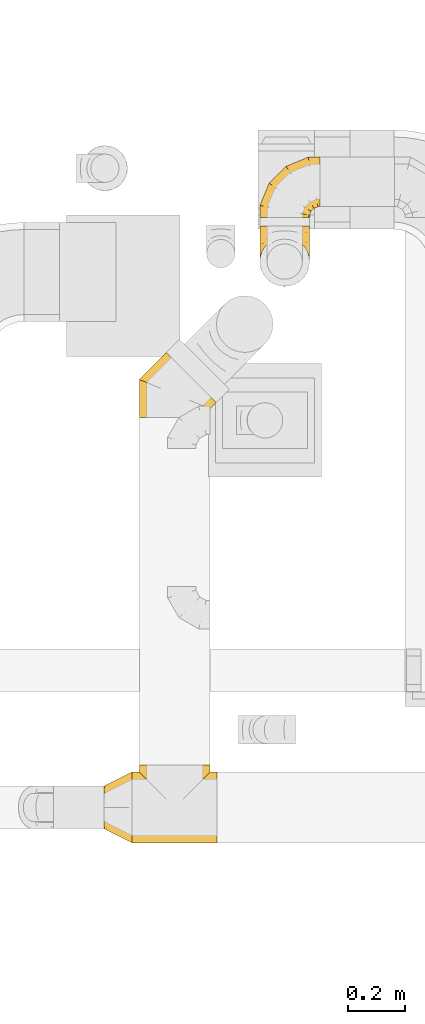
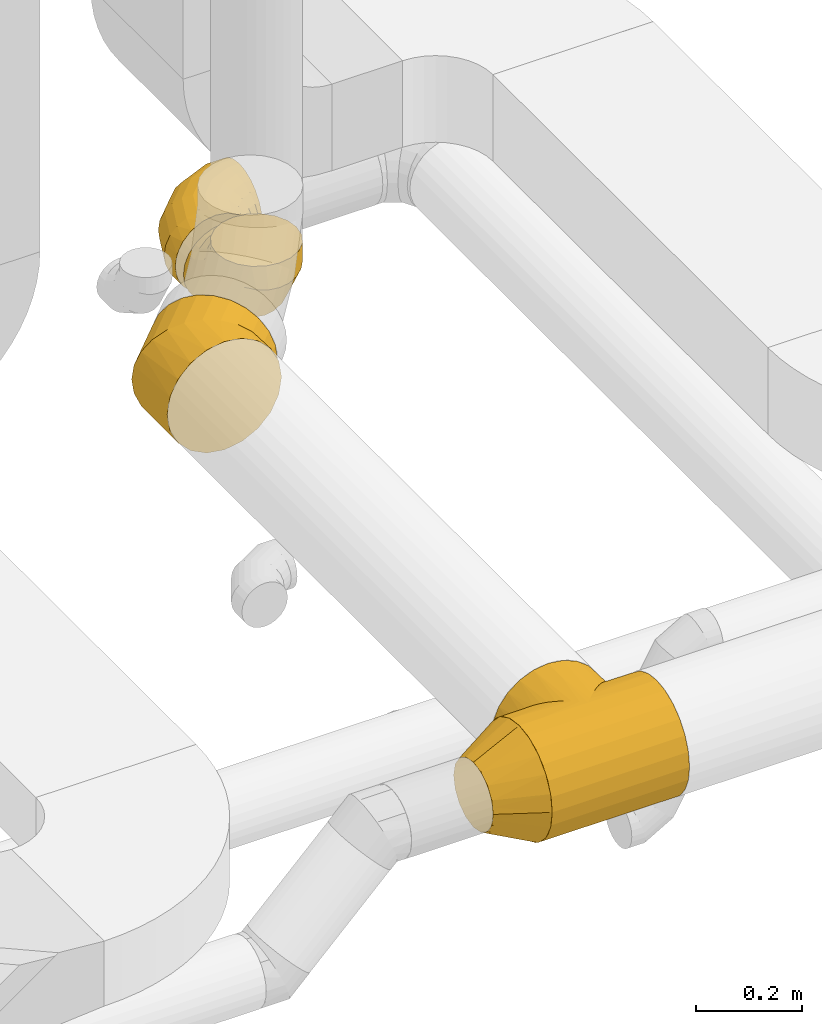
# One storey, part 23 of 97: 5 coverings.
"""IFC2X3 building model written with IfcOpenShell, lengths in millimetres."""

from ifc_helpers import new_model, entity, si_unit, converted_unit, derived_unit, direction, frame, origin, place, context, subcontext, project, spatial, faceted_brep, element, save


model = new_model("IFC2X3")

# Units and contexts
model_context = context("Model", 3, precision=0.01, world=origin(), true_north=direction((6.12303176911189e-17, 1.0)))
body_context = subcontext(model_context, "Body", "Model", "MODEL_VIEW")
ifc_project = project(units=[si_unit("LENGTHUNIT", "METRE", prefix="MILLI"), si_unit("AREAUNIT", "SQUARE_METRE"), si_unit("VOLUMEUNIT", "CUBIC_METRE"), converted_unit("PLANEANGLEUNIT", "DEGREE", entity("IfcRatioMeasure", 0.0174532925199433), si_unit("PLANEANGLEUNIT", "RADIAN"), dimensions=[0, 0, 0, 0, 0, 0, 0]), si_unit("MASSUNIT", "GRAM", prefix="KILO"), derived_unit("MASSDENSITYUNIT", [(si_unit("MASSUNIT", "GRAM", prefix="KILO"), 1), (si_unit("LENGTHUNIT", "METRE"), -3)]), derived_unit("MOMENTOFINERTIAUNIT", [(si_unit("LENGTHUNIT", "METRE"), 4)]), si_unit("TIMEUNIT", "SECOND"), si_unit("FREQUENCYUNIT", "HERTZ"), si_unit("THERMODYNAMICTEMPERATUREUNIT", "DEGREE_CELSIUS"), derived_unit("THERMALTRANSMITTANCEUNIT", [(si_unit("MASSUNIT", "GRAM", prefix="KILO"), 1), (si_unit("THERMODYNAMICTEMPERATUREUNIT", "KELVIN"), -1), (si_unit("TIMEUNIT", "SECOND"), -3)]), derived_unit("VOLUMETRICFLOWRATEUNIT", [(si_unit("LENGTHUNIT", "METRE"), 3), (si_unit("TIMEUNIT", "SECOND"), -1)]), derived_unit("MASSFLOWRATEUNIT", [(si_unit("MASSUNIT", "GRAM", prefix="KILO"), 1), (si_unit("TIMEUNIT", "SECOND"), -1)]), derived_unit("ROTATIONALFREQUENCYUNIT", [(si_unit("TIMEUNIT", "SECOND"), -1)]), si_unit("ELECTRICCURRENTUNIT", "AMPERE"), si_unit("ELECTRICVOLTAGEUNIT", "VOLT"), si_unit("POWERUNIT", "WATT"), si_unit("FORCEUNIT", "NEWTON", prefix="KILO"), si_unit("ILLUMINANCEUNIT", "LUX"), si_unit("LUMINOUSFLUXUNIT", "LUMEN"), si_unit("LUMINOUSINTENSITYUNIT", "CANDELA"), derived_unit("USERDEFINED", [(si_unit("MASSUNIT", "GRAM", prefix="KILO"), -1), (si_unit("LENGTHUNIT", "METRE"), -2), (si_unit("TIMEUNIT", "SECOND"), 3), (si_unit("LUMINOUSFLUXUNIT", "LUMEN"), 1)]), derived_unit("LINEARVELOCITYUNIT", [(si_unit("LENGTHUNIT", "METRE"), 1), (si_unit("TIMEUNIT", "SECOND"), -1)]), si_unit("PRESSUREUNIT", "PASCAL"), derived_unit("USERDEFINED", [(si_unit("LENGTHUNIT", "METRE"), -2), (si_unit("MASSUNIT", "GRAM", prefix="KILO"), 1), (si_unit("TIMEUNIT", "SECOND"), -2)]), derived_unit("LINEARFORCEUNIT", [(si_unit("MASSUNIT", "GRAM", prefix="KILO"), 1), (si_unit("LENGTHUNIT", "METRE"), 1), (si_unit("TIMEUNIT", "SECOND"), -2), (si_unit("LENGTHUNIT", "METRE"), -1)]), derived_unit("PLANARFORCEUNIT", [(si_unit("MASSUNIT", "GRAM", prefix="KILO"), 1), (si_unit("LENGTHUNIT", "METRE"), 1), (si_unit("TIMEUNIT", "SECOND"), -2), (si_unit("LENGTHUNIT", "METRE"), -2)])], contexts=[model_context])

# Site, building, storey
site_placement = place(None, origin())
site = spatial("IfcSite", under=ifc_project, at=site_placement, CompositionType="ELEMENT")
building_placement = place(site_placement, origin())
building = spatial("IfcBuilding", under=site, at=building_placement, CompositionType="ELEMENT")
storey_placement = place(building_placement, frame((0.0, 0.0, -4900.0)))
storey = spatial("IfcBuildingStorey", under=building, at=storey_placement, CompositionType="ELEMENT", Elevation=-4900.0)

# Coverings
covering_1_placement = place(storey_placement, frame((59460.9, 11435.8, 4025.9)))
element("IfcCovering", 1, at=covering_1_placement, inside=storey, PredefinedType="INSULATION", context=body_context, shape_type="Brep", body=[
    faceted_brep([(5.88, 116.13, 214.1), (1.6, 89.1, 214.1), (5.88, 62.06, 214.1), (18.31, 37.66, 214.1), (37.66, 18.31, 214.1), (62.06, 5.88, 214.1), (89.1, 1.6, 214.1), (116.13, 5.88, 214.1), (140.53, 18.31, 214.1), (159.88, 37.66, 214.1), (172.31, 62.06, 214.1), (176.6, 89.1, 214.1), (172.31, 116.13, 214.1), (159.88, 140.53, 214.1), (140.53, 159.88, 214.1), (128.33, 166.1, 214.1), (116.13, 172.31, 214.1), (102.61, 174.45, 214.1), (89.1, 176.6, 214.1), (75.58, 174.45, 214.1), (62.06, 172.31, 214.1), (49.86, 166.1, 214.1), (37.66, 159.88, 214.1), (18.31, 140.53, 214.1), (132.85, 214.1, 13.32), (111.74, 214.1, 4.58), (89.1, 214.1, 1.6), (66.45, 214.1, 4.58), (45.35, 214.1, 13.32), (27.22, 214.1, 27.22), (13.32, 214.1, 45.35), (4.58, 214.1, 66.45), (1.6, 214.1, 89.1), (4.58, 214.1, 111.74), (13.32, 214.1, 132.85), (27.22, 214.1, 150.97), (45.35, 214.1, 164.87), (66.45, 214.1, 173.61), (89.1, 214.1, 176.6), (111.74, 214.1, 173.61), (132.85, 214.1, 164.87), (150.97, 214.1, 150.97), (164.87, 214.1, 132.85), (173.61, 214.1, 111.74), (176.6, 214.1, 89.1), (173.61, 214.1, 66.45), (164.87, 214.1, 45.35), (150.97, 214.1, 27.22), (89.1, 157.16, 1.6), (66.45, 157.95, 4.58), (45.35, 160.3, 13.32), (27.22, 164.02, 27.22), (13.32, 168.88, 45.35), (4.58, 174.53, 66.45), (1.6, 180.6, 89.1), (4.58, 186.67, 111.74), (13.32, 192.32, 132.85), (27.22, 197.18, 150.97), (45.35, 200.91, 164.87), (66.45, 203.25, 173.61), (89.1, 204.05, 176.6), (111.74, 203.25, 173.61), (132.85, 200.91, 164.87), (150.97, 197.18, 150.97), (173.61, 186.67, 111.74), (176.6, 180.6, 89.1), (164.87, 192.32, 132.85), (173.61, 174.53, 66.45), (164.87, 168.88, 45.35), (150.97, 164.02, 27.22), (132.85, 160.3, 13.32), (111.74, 157.95, 4.58), (89.1, 58.53, 58.53), (66.45, 60.72, 60.72), (45.35, 67.12, 67.12), (27.22, 77.3, 77.3), (13.32, 90.56, 90.56), (4.58, 106.01, 106.01), (1.6, 122.59, 122.59), (4.58, 139.17, 139.17), (13.32, 154.62, 154.62), (27.22, 167.88, 167.88), (45.35, 178.06, 178.06), (66.45, 184.46, 184.46), (89.1, 186.64, 186.64), (111.74, 184.46, 184.46), (132.85, 178.06, 178.06), (150.97, 167.88, 167.88), (173.61, 139.17, 139.17), (176.6, 122.59, 122.59), (164.87, 154.62, 154.62), (173.61, 106.01, 106.01), (164.87, 90.56, 90.56), (150.97, 77.3, 77.3), (132.85, 67.12, 67.12), (111.74, 60.72, 60.72), (89.1, 1.6, 157.16), (66.45, 4.58, 157.95), (45.35, 13.32, 160.3), (27.22, 27.22, 164.02), (13.32, 45.35, 168.88), (4.58, 66.45, 174.53), (1.6, 89.1, 180.6), (4.58, 111.74, 186.67), (13.32, 132.85, 192.32), (27.22, 150.97, 197.18), (45.35, 164.87, 200.91), (66.45, 173.61, 203.25), (77.77, 175.1, 203.65), (89.1, 176.6, 204.05), (111.74, 173.61, 203.25), (132.85, 164.87, 200.91), (100.42, 175.1, 203.65), (150.97, 150.97, 197.18), (173.61, 111.74, 186.67), (176.6, 89.1, 180.6), (164.87, 132.85, 192.32), (173.61, 66.45, 174.53), (164.87, 45.35, 168.88), (150.97, 27.22, 164.02), (132.85, 13.32, 160.3), (111.74, 4.58, 157.95)], [[[0, 1, 2, 3, 4, 5, 6, 7, 8, 9, 10, 11, 12, 13, 14, 15, 16, 17, 18, 19, 20, 21, 22, 23]], [[24, 25, 26, 27, 28, 29, 30, 31, 32, 33, 34, 35, 36, 37, 38, 39, 40, 41, 42, 43, 44, 45, 46, 47]], [[26, 48, 49, 27]], [[27, 49, 50, 28]], [[28, 50, 51, 29]], [[30, 52, 53, 31]], [[31, 53, 54, 32]], [[29, 51, 52, 30]], [[55, 56, 34, 33]], [[54, 55, 33, 32]], [[57, 35, 34, 56]], [[58, 59, 37, 36]], [[58, 36, 35, 57]], [[60, 38, 37, 59]], [[61, 62, 40, 39]], [[60, 61, 39, 38]], [[41, 40, 62, 63]], [[64, 65, 44, 43]], [[66, 64, 43, 42]], [[63, 66, 42, 41]], [[46, 45, 67, 68]], [[47, 46, 68, 69]], [[44, 65, 67, 45]], [[25, 24, 70, 71]], [[26, 25, 71, 48]], [[69, 70, 24, 47]], [[49, 48, 72, 73]], [[50, 49, 73, 74]], [[74, 75, 51, 50]], [[52, 51, 75, 76]], [[53, 52, 76, 77]], [[54, 53, 77, 78]], [[79, 80, 56, 55]], [[78, 79, 55, 54]], [[57, 56, 80, 81]], [[82, 83, 59, 58]], [[81, 82, 58, 57]], [[60, 59, 83, 84]], [[85, 86, 62, 61]], [[84, 85, 61, 60]], [[63, 62, 86, 87]], [[88, 89, 65, 64]], [[90, 88, 64, 66]], [[87, 90, 66, 63]], [[67, 65, 89, 91]], [[68, 67, 91, 92]], [[69, 68, 92, 93]], [[71, 70, 94, 95]], [[48, 71, 95, 72]], [[93, 94, 70, 69]], [[73, 72, 96, 97]], [[74, 73, 97, 98]], [[98, 99, 75, 74]], [[76, 75, 99, 100]], [[77, 76, 100, 101]], [[78, 77, 101, 102]], [[103, 104, 80, 79]], [[102, 103, 79, 78]], [[81, 80, 104, 105]], [[106, 107, 83, 82]], [[105, 106, 82, 81]], [[84, 83, 107, 108, 109]], [[110, 111, 86, 85]], [[85, 84, 109, 112, 110]], [[87, 86, 111, 113]], [[114, 115, 89, 88]], [[116, 114, 88, 90]], [[113, 116, 90, 87]], [[91, 89, 115, 117]], [[92, 91, 117, 118]], [[93, 92, 118, 119]], [[95, 94, 120, 121]], [[72, 95, 121, 96]], [[119, 120, 94, 93]], [[97, 6, 5]], [[98, 5, 4]], [[6, 97, 96]], [[97, 5, 98]], [[4, 99, 98]], [[100, 3, 2]], [[101, 2, 1]], [[99, 3, 100]], [[100, 2, 101]], [[1, 102, 101]], [[3, 99, 4]], [[103, 1, 0]], [[104, 0, 23]], [[103, 102, 1]], [[104, 103, 0]], [[23, 105, 104]], [[21, 20, 107]], [[18, 109, 108]], [[107, 20, 19]], [[106, 105, 22]], [[106, 22, 21]], [[107, 19, 108]], [[21, 107, 106]], [[18, 108, 19]], [[22, 105, 23]], [[110, 17, 16]], [[111, 15, 14]], [[18, 112, 109]], [[18, 17, 112]], [[110, 16, 15]], [[110, 15, 111]], [[14, 113, 111]], [[116, 13, 12]], [[114, 12, 11]], [[116, 113, 13]], [[115, 114, 11]], [[116, 12, 114]], [[17, 110, 112]], [[13, 113, 14]], [[117, 11, 10]], [[118, 10, 9]], [[11, 117, 115]], [[117, 10, 118]], [[9, 119, 118]], [[120, 8, 7]], [[121, 7, 6]], [[119, 8, 120]], [[121, 120, 7]], [[96, 121, 6]], [[8, 119, 9]]]),
])
covering_2_placement = place(storey_placement, frame((59460.9, 11680.87, 4025.9)))
element("IfcCovering", 2, at=covering_2_placement, inside=storey, PredefinedType="INSULATION", context=body_context, shape_type="Brep", body=[
    faceted_brep([(116.13, 0.0, 172.31), (89.1, 0.0, 176.6), (62.06, 0.0, 172.31), (37.66, 0.0, 159.88), (18.31, 0.0, 140.53), (5.88, 0.0, 116.13), (1.6, 0.0, 89.1), (5.88, 0.0, 62.06), (18.31, 0.0, 37.66), (37.66, 0.0, 18.31), (62.06, 0.0, 5.88), (89.1, 0.0, 1.6), (116.13, 0.0, 5.88), (140.53, 0.0, 18.31), (159.88, 0.0, 37.66), (166.1, 0.0, 49.86), (172.31, 0.0, 62.06), (174.45, 0.0, 75.58), (176.6, 0.0, 89.1), (174.45, 0.0, 102.61), (172.31, 0.0, 116.13), (166.1, 0.0, 128.33), (159.88, 0.0, 140.53), (140.53, 0.0, 159.88), (214.1, 200.78, 45.35), (214.1, 209.52, 66.45), (214.1, 212.5, 89.1), (214.1, 209.52, 111.74), (214.1, 200.78, 132.85), (214.1, 186.87, 150.97), (214.1, 168.75, 164.87), (214.1, 147.65, 173.61), (214.1, 125.0, 176.6), (214.1, 102.35, 173.61), (214.1, 81.25, 164.87), (214.1, 63.13, 150.97), (214.1, 49.22, 132.85), (214.1, 40.48, 111.74), (214.1, 37.5, 89.1), (214.1, 40.48, 66.45), (214.1, 49.22, 45.35), (214.1, 63.13, 27.22), (214.1, 81.25, 13.32), (214.1, 102.35, 4.58), (214.1, 125.0, 1.6), (214.1, 147.65, 4.58), (214.1, 168.75, 13.32), (214.1, 186.87, 27.22), (171.83, 212.5, 89.1), (172.42, 209.52, 111.74), (174.16, 200.78, 132.85), (176.92, 186.87, 150.97), (180.53, 168.75, 164.87), (184.73, 147.65, 173.61), (189.23, 125.0, 176.6), (193.74, 102.35, 173.61), (197.93, 81.25, 164.87), (201.54, 63.13, 150.97), (206.04, 40.48, 111.74), (206.64, 37.5, 89.1), (204.3, 49.22, 132.85), (204.3, 49.22, 45.35), (201.54, 63.13, 27.22), (206.04, 40.48, 66.45), (193.74, 102.35, 4.58), (189.23, 125.0, 1.6), (197.93, 81.25, 13.32), (184.73, 147.65, 4.58), (180.53, 168.75, 13.32), (176.92, 186.87, 27.22), (174.16, 200.78, 45.35), (172.42, 209.52, 66.45), (93.72, 180.15, 89.1), (95.41, 177.62, 111.74), (100.36, 170.21, 132.85), (108.24, 158.42, 150.97), (118.51, 143.06, 164.87), (130.46, 125.17, 173.61), (143.29, 105.97, 176.6), (156.12, 86.77, 173.61), (168.07, 68.88, 164.87), (178.34, 53.52, 150.97), (191.16, 34.32, 111.74), (192.85, 31.79, 89.1), (186.21, 41.73, 132.85), (186.21, 41.73, 45.35), (178.34, 53.52, 27.22), (191.16, 34.32, 66.45), (156.12, 86.77, 4.58), (143.29, 105.97, 1.6), (168.07, 68.88, 13.32), (130.46, 125.17, 4.58), (118.51, 143.06, 13.32), (108.24, 158.42, 27.22), (100.36, 170.21, 45.35), (95.41, 177.62, 66.45), (33.95, 120.37, 89.1), (36.47, 118.68, 111.74), (43.88, 113.73, 132.85), (55.67, 105.85, 150.97), (71.04, 95.59, 164.87), (88.93, 83.64, 173.61), (108.13, 70.81, 176.6), (127.32, 57.98, 173.61), (145.21, 46.02, 164.87), (160.58, 35.76, 150.97), (179.78, 22.93, 111.74), (182.3, 21.24, 89.1), (172.37, 27.88, 132.85), (172.37, 27.88, 45.35), (160.58, 35.76, 27.22), (179.78, 22.93, 66.45), (127.32, 57.98, 4.58), (108.13, 70.81, 1.6), (145.21, 46.02, 13.32), (88.93, 83.64, 4.58), (71.04, 95.59, 13.32), (55.67, 105.85, 27.22), (43.88, 113.73, 45.35), (36.47, 118.68, 66.45), (1.6, 42.27, 89.1), (4.58, 41.68, 111.74), (13.32, 39.94, 132.85), (27.22, 37.17, 150.97), (45.35, 33.57, 164.87), (66.45, 29.37, 173.61), (89.1, 24.86, 176.6), (111.74, 20.36, 173.61), (132.85, 16.16, 164.87), (150.97, 12.56, 150.97), (173.61, 8.05, 111.74), (175.1, 7.76, 100.42), (176.6, 7.46, 89.1), (164.87, 9.79, 132.85), (164.87, 9.79, 45.35), (150.97, 12.56, 27.22), (173.61, 8.05, 66.45), (175.1, 7.76, 77.77), (111.74, 20.36, 4.58), (89.1, 24.86, 1.6), (132.85, 16.16, 13.32), (66.45, 29.37, 4.58), (45.35, 33.57, 13.32), (27.22, 37.17, 27.22), (13.32, 39.94, 45.35), (4.58, 41.68, 66.45)], [[[0, 1, 2, 3, 4, 5, 6, 7, 8, 9, 10, 11, 12, 13, 14, 15, 16, 17, 18, 19, 20, 21, 22, 23]], [[24, 25, 26, 27, 28, 29, 30, 31, 32, 33, 34, 35, 36, 37, 38, 39, 40, 41, 42, 43, 44, 45, 46, 47]], [[26, 48, 49, 27]], [[27, 49, 50, 28]], [[28, 50, 51, 29]], [[30, 52, 53, 31]], [[31, 53, 54, 32]], [[30, 29, 51, 52]], [[55, 56, 34, 33]], [[54, 55, 33, 32]], [[34, 56, 57, 35]], [[58, 59, 38, 37]], [[60, 58, 37, 36]], [[35, 57, 60, 36]], [[40, 61, 62, 41]], [[63, 61, 40, 39]], [[38, 59, 63, 39]], [[64, 65, 44, 43]], [[66, 64, 43, 42]], [[62, 66, 42, 41]], [[46, 45, 67, 68]], [[47, 46, 68, 69]], [[44, 65, 67, 45]], [[25, 24, 70, 71]], [[26, 25, 71, 48]], [[69, 70, 24, 47]], [[49, 48, 72, 73]], [[50, 49, 73, 74]], [[74, 75, 51, 50]], [[52, 51, 75, 76]], [[53, 52, 76, 77]], [[54, 53, 77, 78]], [[79, 80, 56, 55]], [[78, 79, 55, 54]], [[56, 80, 81, 57]], [[82, 83, 59, 58]], [[84, 82, 58, 60]], [[60, 57, 81, 84]], [[85, 86, 62, 61]], [[87, 85, 61, 63]], [[83, 87, 63, 59]], [[88, 89, 65, 64]], [[90, 88, 64, 66]], [[66, 62, 86, 90]], [[67, 65, 89, 91]], [[68, 67, 91, 92]], [[69, 68, 92, 93]], [[71, 70, 94, 95]], [[48, 71, 95, 72]], [[93, 94, 70, 69]], [[73, 72, 96, 97]], [[74, 73, 97, 98]], [[98, 99, 75, 74]], [[76, 75, 99, 100]], [[77, 76, 100, 101]], [[78, 77, 101, 102]], [[103, 104, 80, 79]], [[102, 103, 79, 78]], [[80, 104, 105, 81]], [[106, 107, 83, 82]], [[108, 106, 82, 84]], [[84, 81, 105, 108]], [[109, 110, 86, 85]], [[111, 109, 85, 87]], [[107, 111, 87, 83]], [[112, 113, 89, 88]], [[114, 112, 88, 90]], [[90, 86, 110, 114]], [[91, 89, 113, 115]], [[92, 91, 115, 116]], [[93, 92, 116, 117]], [[95, 94, 118, 119]], [[72, 95, 119, 96]], [[117, 118, 94, 93]], [[97, 96, 120, 121]], [[98, 97, 121, 122]], [[122, 123, 99, 98]], [[100, 99, 123, 124]], [[101, 100, 124, 125]], [[102, 101, 125, 126]], [[127, 128, 104, 103]], [[126, 127, 103, 102]], [[104, 128, 129, 105]], [[107, 106, 130, 131, 132]], [[133, 130, 106, 108]], [[108, 105, 129, 133]], [[134, 135, 110, 109]], [[136, 134, 109, 111]], [[107, 132, 137, 136, 111]], [[138, 139, 113, 112]], [[140, 138, 112, 114]], [[114, 110, 135, 140]], [[115, 113, 139, 141]], [[116, 115, 141, 142]], [[117, 116, 142, 143]], [[119, 118, 144, 145]], [[96, 119, 145, 120]], [[143, 144, 118, 117]], [[121, 6, 5]], [[122, 5, 4]], [[6, 121, 120]], [[121, 5, 122]], [[4, 123, 122]], [[2, 1, 125]], [[3, 2, 124]], [[123, 3, 124]], [[124, 2, 125]], [[1, 126, 125]], [[3, 123, 4]], [[127, 1, 0]], [[128, 0, 23]], [[127, 126, 1]], [[128, 127, 0]], [[23, 129, 128]], [[21, 20, 130]], [[18, 132, 131]], [[130, 20, 19]], [[133, 129, 22]], [[133, 22, 21]], [[130, 19, 131]], [[21, 130, 133]], [[18, 131, 19]], [[22, 129, 23]], [[136, 17, 16]], [[134, 15, 14]], [[18, 137, 132]], [[18, 17, 137]], [[136, 16, 15]], [[136, 15, 134]], [[14, 135, 134]], [[140, 13, 12]], [[138, 12, 11]], [[140, 135, 13]], [[139, 138, 11]], [[140, 12, 138]], [[17, 136, 137]], [[13, 135, 14]], [[141, 11, 10]], [[142, 10, 9]], [[11, 141, 139]], [[141, 10, 142]], [[9, 143, 142]], [[144, 8, 7]], [[145, 7, 6]], [[143, 8, 144]], [[145, 144, 7]], [[120, 145, 6]], [[8, 143, 9]]]),
])
covering_3_placement = place(storey_placement, frame((59035.41, 10974.41, 4223.4)))
element("IfcCovering", 3, at=covering_3_placement, inside=storey, PredefinedType="INSULATION", context=body_context, shape_type="Brep", body=[
    faceted_brep([(251.6, 0.0, 126.6), (245.48, 0.0, 165.22), (227.72, 0.0, 200.07), (200.07, 0.0, 227.72), (165.22, 0.0, 245.48), (126.6, 0.0, 251.6), (87.97, 0.0, 245.48), (53.12, 0.0, 227.72), (25.47, 0.0, 200.07), (7.71, 0.0, 165.22), (1.6, 0.0, 126.6), (7.71, 0.0, 87.97), (25.47, 0.0, 53.12), (53.12, 0.0, 25.47), (87.97, 0.0, 7.71), (126.6, 0.0, 1.6), (165.22, 0.0, 7.71), (200.07, 0.0, 25.47), (227.72, 0.0, 53.12), (245.48, 0.0, 87.97), (99.8, 226.8, 94.24), (96.79, 229.81, 126.6), (99.8, 226.8, 158.95), (108.63, 217.97, 189.1), (122.67, 203.92, 214.98), (140.98, 185.62, 234.85), (162.3, 164.3, 247.34), (185.17, 141.42, 251.6), (208.05, 118.54, 247.34), (229.37, 97.23, 234.85), (247.67, 78.92, 214.98), (261.72, 64.87, 189.1), (270.55, 56.04, 158.95), (273.56, 53.03, 126.6), (270.55, 56.04, 94.24), (261.72, 64.87, 64.1), (247.67, 78.92, 38.21), (229.37, 97.23, 18.34), (208.05, 118.54, 5.85), (185.17, 141.42, 1.6), (162.3, 164.3, 5.85), (140.98, 185.62, 18.34), (122.67, 203.92, 38.21), (108.63, 217.97, 64.1), (1.6, 134.62, 126.6), (5.85, 132.86, 158.95), (18.34, 127.68, 189.1), (38.21, 119.45, 214.98), (64.1, 108.73, 234.85), (94.24, 96.24, 247.34), (126.6, 82.84, 251.6), (158.95, 69.44, 247.34), (189.1, 56.95, 234.85), (214.98, 46.23, 214.98), (247.34, 32.83, 158.95), (251.6, 31.07, 126.6), (234.85, 38.0, 189.1), (234.85, 38.0, 64.1), (214.98, 46.23, 38.21), (247.34, 32.83, 94.24), (158.95, 69.44, 5.85), (126.6, 82.84, 1.6), (189.1, 56.95, 18.34), (94.24, 96.24, 5.85), (64.1, 108.73, 18.34), (38.21, 119.45, 38.21), (18.34, 127.68, 64.1), (5.85, 132.86, 94.24)], [[[0, 1, 2, 3, 4, 5, 6, 7, 8, 9, 10, 11, 12, 13, 14, 15, 16, 17, 18, 19]], [[20, 21, 22, 23, 24, 25, 26, 27, 28, 29, 30, 31, 32, 33, 34, 35, 36, 37, 38, 39, 40, 41, 42, 43]], [[21, 44, 45, 22]], [[22, 45, 46, 23]], [[47, 24, 23, 46]], [[24, 47, 48, 25]], [[25, 48, 49, 26]], [[50, 27, 26, 49]], [[51, 52, 29, 28]], [[50, 51, 28, 27]], [[29, 52, 53, 30]], [[54, 55, 33, 32]], [[56, 54, 32, 31]], [[30, 53, 56, 31]], [[35, 57, 58, 36]], [[59, 57, 35, 34]], [[33, 55, 59, 34]], [[60, 61, 39, 38]], [[62, 60, 38, 37]], [[58, 62, 37, 36]], [[40, 39, 61, 63]], [[41, 40, 63, 64]], [[64, 65, 42, 41]], [[20, 43, 66, 67]], [[21, 20, 67, 44]], [[65, 66, 43, 42]], [[9, 8, 46]], [[10, 9, 45]], [[10, 45, 44]], [[45, 9, 46]], [[8, 47, 46]], [[48, 7, 6]], [[49, 6, 5]], [[47, 7, 48]], [[48, 6, 49]], [[5, 50, 49]], [[7, 47, 8]], [[4, 3, 52]], [[5, 4, 51]], [[51, 50, 5]], [[52, 51, 4]], [[3, 53, 52]], [[56, 2, 1]], [[54, 1, 0]], [[56, 53, 2]], [[55, 54, 0]], [[56, 1, 54]], [[2, 53, 3]], [[19, 18, 57]], [[0, 19, 59]], [[59, 55, 0]], [[57, 59, 19]], [[18, 58, 57]], [[62, 17, 16]], [[60, 16, 15]], [[62, 58, 17]], [[61, 60, 15]], [[62, 16, 60]], [[17, 58, 18]], [[63, 15, 14]], [[64, 14, 13]], [[15, 63, 61]], [[63, 14, 64]], [[13, 65, 64]], [[66, 12, 11]], [[67, 11, 10]], [[65, 12, 66]], [[67, 66, 11]], [[44, 67, 10]], [[12, 65, 13]]]),
])
covering_4_placement = place(storey_placement, frame((59012.01, 9472.39, 4223.4)))
element("IfcCovering", 4, at=covering_4_placement, inside=storey, PredefinedType="INSULATION", context=body_context, shape_type="Brep", body=[
    faceted_brep([(247.6, 126.6, 251.6), (300.0, 158.95, 247.34), (172.44, 149.03, 249.57), (300.0, 189.1, 234.85), (225.83, 202.43, 225.96), (215.72, 192.31, 232.93), (300.0, 214.98, 214.98), (205.24, 181.84, 238.73), (300.0, 126.6, 251.6), (0.0, 158.95, 247.34), (0.0, 126.6, 251.6), (52.4, 126.6, 251.6), (161.24, 137.84, 251.09), (194.49, 171.09, 243.41), (183.54, 160.13, 247.01), (300.0, 234.85, 189.1), (252.86, 229.45, 197.63), (300.0, 224.92, 202.04), (300.0, 247.34, 158.95), (266.36, 242.96, 172.25), (300.0, 241.09, 174.02), (273.99, 250.59, 142.43), (300.0, 251.6, 126.6), (275.0, 251.6, 126.6), (26.01, 250.59, 142.43), (25.0, 251.6, 126.6), (0.0, 251.6, 126.6), (300.0, 249.47, 142.77), (244.55, 221.14, 208.36), (271.05, 247.64, 157.78), (235.49, 212.08, 217.79), (150.0, 126.6, 251.6), (138.76, 137.84, 251.09), (260.21, 236.81, 185.58), (300.0, 249.47, 110.42), (0.0, 249.47, 110.42), (265.16, 241.75, 77.98), (300.0, 241.09, 79.17), (300.0, 234.85, 64.1), (300.0, 247.34, 94.24), (273.84, 250.44, 109.63), (300.0, 224.92, 51.15), (300.0, 214.98, 38.21), (240.75, 217.35, 40.63), (270.48, 247.07, 93.27), (258.22, 234.81, 64.04), (249.99, 226.58, 51.58), (230.73, 207.32, 31.16), (220.11, 196.7, 23.11), (300.0, 189.1, 18.34), (197.59, 174.18, 11.01), (300.0, 158.95, 5.85), (209.02, 185.62, 16.41), (174.03, 150.62, 3.93), (300.0, 126.6, 1.6), (185.9, 162.49, 6.86), (162.04, 138.64, 2.18), (150.0, 126.6, 1.6), (137.96, 138.64, 2.18), (0.0, 126.6, 1.6), (0.0, 18.34, 64.1), (0.0, 5.85, 94.24), (0.0, 1.6, 126.6), (0.0, 5.85, 158.95), (0.0, 18.34, 189.1), (0.0, 38.21, 214.98), (0.0, 64.1, 234.85), (0.0, 94.24, 247.34), (0.0, 189.1, 234.85), (0.0, 214.98, 214.98), (0.0, 224.92, 202.04), (0.0, 234.85, 189.1), (0.0, 241.09, 174.02), (0.0, 247.34, 158.95), (0.0, 249.47, 142.77), (0.0, 247.34, 94.24), (0.0, 241.09, 79.17), (0.0, 234.85, 64.1), (0.0, 224.92, 51.15), (0.0, 214.98, 38.21), (0.0, 189.1, 18.34), (0.0, 158.95, 5.85), (0.0, 94.24, 5.85), (0.0, 64.1, 18.34), (0.0, 38.21, 38.21), (300.0, 94.24, 247.34), (300.0, 64.1, 234.85), (300.0, 38.21, 214.98), (300.0, 18.34, 189.1), (300.0, 5.85, 158.95), (300.0, 1.6, 126.6), (300.0, 5.85, 94.24), (300.0, 18.34, 64.1), (300.0, 38.21, 38.21), (300.0, 64.1, 18.34), (300.0, 94.24, 5.85), (116.46, 160.13, 247.01), (105.51, 171.09, 243.41), (127.56, 149.03, 249.57), (94.76, 181.84, 238.73), (84.28, 192.31, 232.93), (74.17, 202.43, 225.96), (47.14, 229.45, 197.63), (55.45, 221.14, 208.36), (64.51, 212.08, 217.79), (33.64, 242.96, 172.25), (28.95, 247.64, 157.78), (39.79, 236.81, 185.58), (34.84, 241.75, 77.98), (29.52, 247.07, 93.27), (26.16, 250.44, 109.63), (59.25, 217.35, 40.63), (50.01, 226.58, 51.58), (41.78, 234.81, 64.04), (69.27, 207.32, 31.16), (102.41, 174.18, 11.01), (114.1, 162.49, 6.86), (125.97, 150.62, 3.93), (79.89, 196.7, 23.11), (90.98, 185.62, 16.41), (182.35, 276.6, 247.34), (212.5, 276.6, 234.85), (238.39, 276.6, 214.98), (248.32, 276.6, 202.04), (258.25, 276.6, 189.1), (264.5, 276.6, 174.02), (270.74, 276.6, 158.95), (272.87, 276.6, 142.77), (275.0, 276.6, 126.6), (272.87, 276.6, 110.42), (270.74, 276.6, 94.24), (264.5, 276.6, 79.17), (258.25, 276.6, 64.1), (248.32, 276.6, 51.15), (238.39, 276.6, 38.21), (212.5, 276.6, 18.34), (182.35, 276.6, 5.85), (150.0, 276.6, 1.6), (117.65, 276.6, 5.85), (87.5, 276.6, 18.34), (61.61, 276.6, 38.21), (51.68, 276.6, 51.15), (41.75, 276.6, 64.1), (35.5, 276.6, 79.17), (29.26, 276.6, 94.24), (27.13, 276.6, 110.42), (25.0, 276.6, 126.6), (27.13, 276.6, 142.77), (29.26, 276.6, 158.95), (35.5, 276.6, 174.02), (41.75, 276.6, 189.1), (51.68, 276.6, 202.04), (61.61, 276.6, 214.98), (87.5, 276.6, 234.85), (117.65, 276.6, 247.34), (150.0, 276.6, 251.6), (150.0, 224.19, 251.6)], [[[0, 1, 2]], [[3, 4, 5]], [[4, 3, 6]], [[1, 3, 7]], [[5, 7, 3]], [[8, 1, 0]], [[9, 10, 11]], [[12, 0, 2]], [[13, 14, 1]], [[7, 13, 1]], [[2, 1, 14]], [[15, 16, 17]], [[18, 19, 20]], [[21, 22, 23]], [[24, 25, 26]], [[22, 21, 27]], [[28, 17, 16]], [[29, 18, 27]], [[28, 30, 6]], [[28, 6, 17]], [[12, 31, 0]], [[31, 32, 11]], [[33, 20, 19]], [[33, 15, 20]], [[29, 19, 18]], [[29, 27, 21]], [[16, 15, 33]], [[6, 30, 4]], [[23, 22, 34]], [[25, 35, 26]], [[36, 37, 38]], [[34, 39, 40]], [[41, 42, 43]], [[44, 37, 36]], [[44, 40, 39]], [[44, 39, 37]], [[45, 41, 46]], [[45, 38, 41]], [[46, 41, 43]], [[36, 38, 45]], [[23, 34, 40]], [[42, 47, 43]], [[48, 47, 49]], [[50, 49, 51]], [[49, 52, 48]], [[47, 42, 49]], [[53, 51, 54]], [[50, 52, 49]], [[55, 50, 51]], [[56, 53, 54]], [[57, 56, 54]], [[58, 57, 59]], [[55, 51, 53]], [[60, 61, 62, 63, 64, 65, 66, 67, 10, 9, 68, 69, 70, 71, 72, 73, 74, 26, 35, 75, 76, 77, 78, 79, 80, 81, 59, 82, 83, 84]], [[85, 86, 87, 88, 89, 90, 91, 92, 93, 94, 95, 54, 51, 49, 42, 41, 38, 37, 39, 34, 22, 27, 18, 20, 15, 17, 6, 3, 1, 8]], [[88, 87, 65, 64]], [[62, 90, 89, 63]], [[63, 89, 88, 64]], [[66, 86, 85, 67]], [[85, 8, 0, 31, 11, 10, 67]], [[65, 87, 86, 66]], [[96, 97, 9]], [[98, 96, 9]], [[9, 11, 98]], [[9, 97, 99]], [[9, 99, 68]], [[68, 100, 101]], [[100, 68, 99]], [[68, 101, 69]], [[98, 11, 32]], [[102, 70, 103]], [[104, 103, 69]], [[105, 73, 72]], [[102, 71, 70]], [[105, 106, 73]], [[105, 72, 107]], [[102, 107, 71]], [[72, 71, 107]], [[69, 103, 70]], [[24, 26, 74]], [[74, 73, 106]], [[74, 106, 24]], [[104, 69, 101]], [[108, 76, 109]], [[110, 75, 35]], [[111, 79, 78]], [[112, 78, 113]], [[108, 77, 76]], [[108, 113, 77]], [[110, 35, 25]], [[111, 78, 112]], [[109, 75, 110]], [[76, 75, 109]], [[78, 77, 113]], [[111, 114, 79]], [[115, 116, 81]], [[117, 58, 59]], [[116, 117, 81]], [[114, 118, 80]], [[80, 118, 119]], [[114, 80, 79]], [[81, 80, 115]], [[81, 117, 59]], [[115, 80, 119]], [[57, 54, 95, 82, 59]], [[82, 95, 94, 83]], [[94, 93, 84, 83]], [[84, 93, 92, 60]], [[60, 92, 91, 61]], [[61, 91, 90, 62]], [[120, 121, 122, 123, 124, 125, 126, 127, 128, 129, 130, 131, 132, 133, 134, 135, 136, 137, 138, 139, 140, 141, 142, 143, 144, 145, 146, 147, 148, 149, 150, 151, 152, 153, 154, 155]], [[21, 23, 128]], [[125, 124, 33]], [[127, 126, 29]], [[123, 122, 28]], [[19, 126, 125]], [[21, 127, 29]], [[19, 29, 126]], [[16, 124, 123]], [[16, 33, 124]], [[16, 123, 28]], [[2, 156, 12]], [[125, 33, 19]], [[21, 128, 127]], [[122, 30, 28]], [[30, 122, 4]], [[5, 4, 121]], [[7, 121, 120]], [[121, 7, 5]], [[122, 121, 4]], [[120, 155, 156]], [[13, 7, 120]], [[14, 13, 120]], [[120, 156, 2]], [[31, 12, 156]], [[14, 120, 2]], [[156, 154, 98]], [[153, 101, 100]], [[101, 153, 152]], [[154, 153, 99]], [[100, 99, 153]], [[155, 154, 156]], [[32, 156, 98]], [[97, 96, 154]], [[99, 97, 154]], [[98, 154, 96]], [[150, 102, 151]], [[148, 105, 149]], [[24, 146, 25]], [[146, 24, 147]], [[103, 151, 102]], [[106, 148, 147]], [[103, 104, 152]], [[103, 152, 151]], [[32, 31, 156]], [[107, 149, 105]], [[107, 150, 149]], [[106, 105, 148]], [[106, 147, 24]], [[102, 150, 107]], [[152, 104, 101]], [[25, 146, 145]], [[108, 143, 142]], [[145, 144, 110]], [[141, 140, 111]], [[109, 143, 108]], [[109, 110, 144]], [[109, 144, 143]], [[113, 141, 112]], [[113, 142, 141]], [[112, 141, 111]], [[108, 142, 113]], [[25, 145, 110]], [[140, 114, 111]], [[118, 114, 139]], [[115, 139, 138]], [[139, 119, 118]], [[114, 140, 139]], [[117, 138, 137]], [[115, 119, 139]], [[116, 115, 138]], [[58, 117, 137]], [[57, 58, 137]], [[116, 138, 117]], [[53, 137, 136]], [[135, 47, 48]], [[47, 135, 134]], [[136, 135, 50]], [[48, 52, 135]], [[56, 57, 137]], [[53, 56, 137]], [[50, 55, 136]], [[52, 50, 135]], [[53, 136, 55]], [[133, 132, 45]], [[129, 128, 23]], [[130, 44, 131]], [[23, 40, 129]], [[43, 134, 133]], [[46, 133, 45]], [[40, 130, 129]], [[43, 133, 46]], [[36, 131, 44]], [[40, 44, 130]], [[36, 132, 131]], [[45, 132, 36]], [[134, 43, 47]]]),
])
covering_5_placement = place(storey_placement, frame((58912.01, 9472.39, 4223.4)))
element("IfcCovering", 5, at=covering_5_placement, inside=storey, PredefinedType="INSULATION", context=body_context, shape_type="Brep", body=[
    faceted_brep([(100.0, 87.97, 245.48), (100.0, 53.12, 227.72), (100.0, 25.47, 200.07), (100.0, 7.71, 165.22), (100.0, 1.6, 126.6), (100.0, 7.71, 87.97), (100.0, 25.47, 53.12), (100.0, 53.12, 25.47), (100.0, 87.97, 7.71), (100.0, 126.6, 1.6), (100.0, 165.22, 7.71), (100.0, 200.07, 25.47), (100.0, 227.72, 53.12), (100.0, 245.48, 87.97), (100.0, 251.6, 126.6), (100.0, 245.48, 165.22), (100.0, 227.72, 200.07), (100.0, 200.07, 227.72), (100.0, 165.22, 245.48), (100.0, 126.6, 251.6), (0.0, 140.95, 198.74), (0.0, 155.3, 195.89), (0.0, 167.46, 187.76), (0.0, 179.63, 179.63), (0.0, 187.76, 167.46), (0.0, 195.89, 155.3), (0.0, 198.74, 140.95), (0.0, 201.6, 126.6), (0.0, 198.74, 112.24), (0.0, 195.89, 97.89), (0.0, 187.76, 85.73), (0.0, 179.63, 73.56), (0.0, 167.46, 65.43), (0.0, 155.3, 57.3), (0.0, 140.95, 54.45), (0.0, 126.6, 51.6), (0.0, 112.24, 54.45), (0.0, 97.89, 57.3), (0.0, 85.73, 65.43), (0.0, 73.56, 73.56), (0.0, 65.43, 85.73), (0.0, 57.3, 97.89), (0.0, 54.45, 112.24), (0.0, 51.6, 126.6), (0.0, 54.45, 140.95), (0.0, 57.3, 155.3), (0.0, 65.43, 167.46), (0.0, 73.56, 179.63), (0.0, 85.73, 187.76), (0.0, 97.89, 195.89), (0.0, 112.24, 198.74), (0.0, 126.6, 201.6)], [[[0, 1, 2, 3, 4, 5, 6, 7, 8, 9, 10, 11, 12, 13, 14, 15, 16, 17, 18, 19]], [[20, 21, 22, 23, 24, 25, 26, 27, 28, 29, 30, 31, 32, 33, 34, 35, 36, 37, 38, 39, 40, 41, 42, 43, 44, 45, 46, 47, 48, 49, 50, 51]], [[4, 42, 5]], [[42, 4, 43]], [[41, 6, 5]], [[8, 37, 36]], [[42, 41, 5]], [[6, 41, 40, 39]], [[7, 39, 38, 37]], [[9, 36, 35]], [[8, 7, 37]], [[9, 8, 36]], [[39, 7, 6]], [[9, 34, 10]], [[34, 9, 35]], [[33, 11, 10]], [[13, 29, 28]], [[34, 33, 10]], [[11, 33, 32, 31]], [[12, 31, 30, 29]], [[14, 28, 27]], [[13, 12, 29]], [[14, 13, 28]], [[31, 12, 11]], [[14, 26, 15]], [[26, 14, 27]], [[25, 16, 15]], [[18, 21, 20]], [[26, 25, 15]], [[16, 25, 24, 23]], [[17, 23, 22, 21]], [[19, 20, 51]], [[18, 17, 21]], [[19, 18, 20]], [[23, 17, 16]], [[19, 50, 0]], [[50, 19, 51]], [[49, 1, 0]], [[3, 45, 44]], [[50, 49, 0]], [[1, 49, 48, 47]], [[2, 47, 46, 45]], [[4, 44, 43]], [[3, 2, 45]], [[4, 3, 44]], [[47, 2, 1]]]),
])

save(model, "model.ifc")
